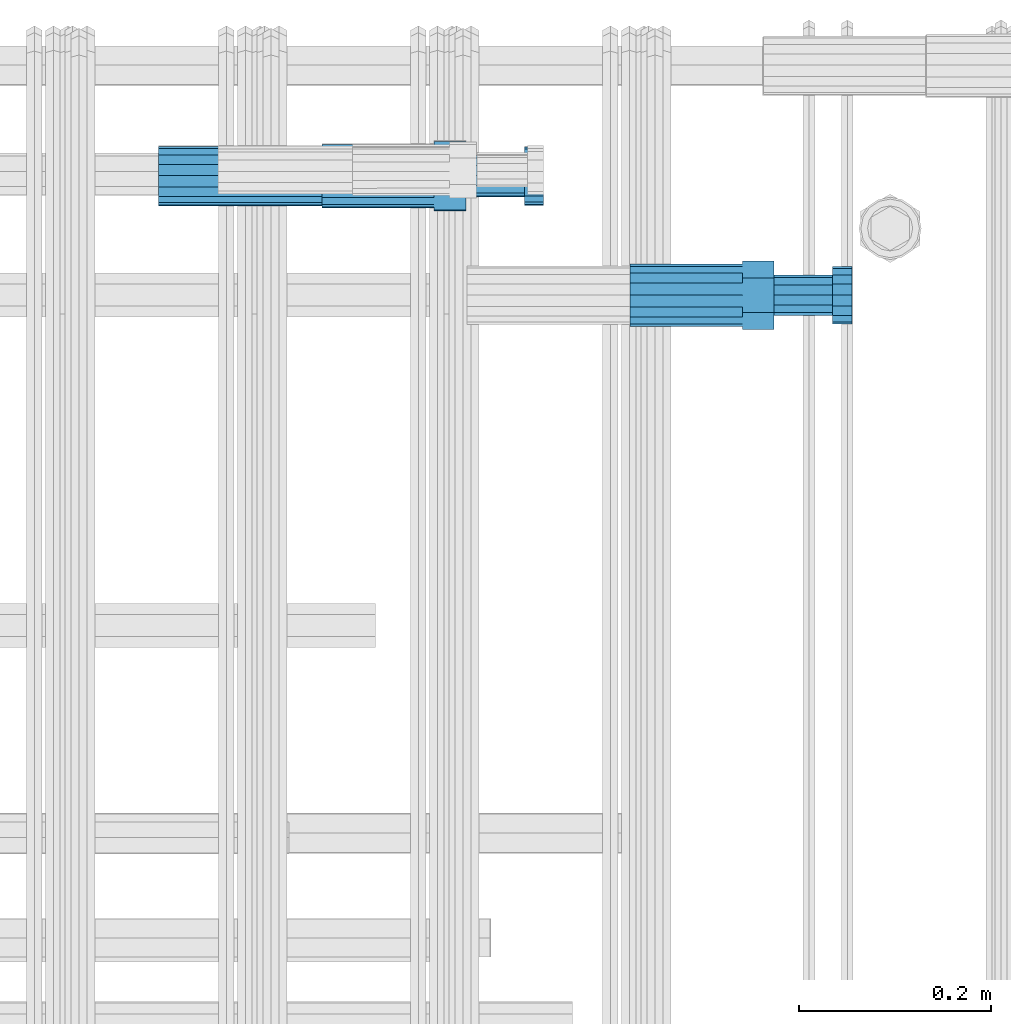
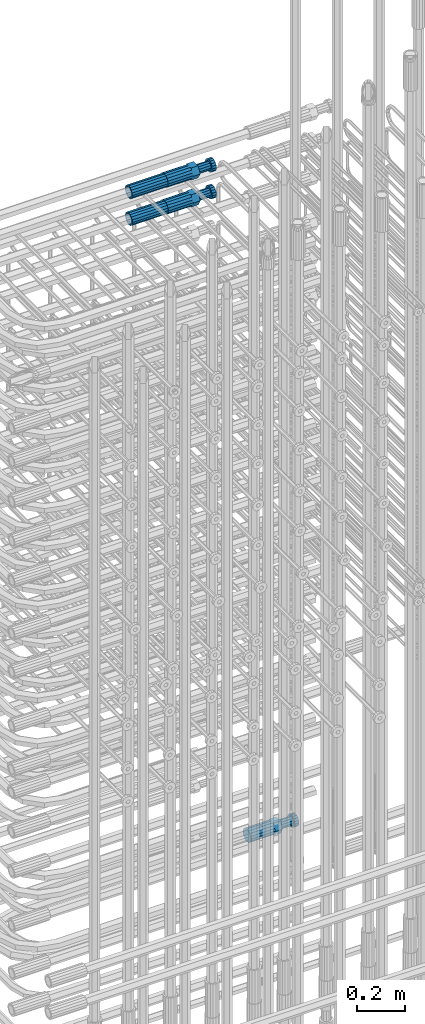
# One storey, part 44 of 177: 5 beams.
"""IFC2X3 building model written with IfcOpenShell, lengths in millimetres."""

from ifc_helpers import new_model, si_unit, frame, origin_with_axes, place, context, subcontext, project, spatial, faceted_brep, material, type_object, element, save


model = new_model("IFC2X3")

# Units and contexts
model_context_1 = context("Model", 3, precision=1e-05, world=origin_with_axes())
model_context_2 = context("Model", 3, precision=1e-05, world=origin_with_axes())
body_context = subcontext(model_context_2, "Body", "Model", "MODEL_VIEW")
ifc_project = project(units=[si_unit("LENGTHUNIT", "METRE", prefix="MILLI"), si_unit("AREAUNIT", "SQUARE_METRE"), si_unit("VOLUMEUNIT", "CUBIC_METRE"), si_unit("MASSUNIT", "GRAM", prefix="KILO"), si_unit("TIMEUNIT", "SECOND"), si_unit("PLANEANGLEUNIT", "RADIAN"), si_unit("SOLIDANGLEUNIT", "STERADIAN"), si_unit("THERMODYNAMICTEMPERATUREUNIT", "DEGREE_CELSIUS"), si_unit("LUMINOUSINTENSITYUNIT", "LUMEN")], contexts=[model_context_1])

# Site, building, storey
site_placement = place(None, origin_with_axes())
site = spatial("IfcSite", under=ifc_project, at=site_placement, CompositionType="ELEMENT")
building_placement = place(site_placement, origin_with_axes())
building = spatial("IfcBuilding", under=site, at=building_placement, Name="Undefined", CompositionType="ELEMENT")
storey_placement = place(building_placement, origin_with_axes())
storey = spatial("IfcBuildingStorey", under=building, at=storey_placement, Name="Undefined", CompositionType="ELEMENT", Elevation=0.0)

# Beams
ifc_material = material(Name="STEEL/S275")
beam_type_1 = type_object("IfcBeamType", PredefinedType="NOTDEFINED")
beam_1_placement = place(storey_placement, frame((2030819.00847313, 6206283.98588031, 22354.9868004314), z_axis=(0.0, 0.0, -1.0), x_axis=(1.0, 0.0, 0.0)))
element("IfcBeam", 1, at=beam_1_placement, inside=storey, type_object=beam_type_1, material=ifc_material, Name="AG40N", context=body_context, shape_type="Brep", body=[
    faceted_brep([(0.0, -23.5000000001164, -9.31322574615479e-10), (0.0, -21.7111690140155, 8.99306066054851), (170.0, -21.7111690140155, 8.99306066054851), (170.0, -23.5, 0.0), (0.0, -16.6170093578839, 16.6170093575493), (170.0, -16.6170093578839, 16.6170093575493), (0.0, -8.99306066057943, 21.7111690137535), (170.0, -8.99306066057943, 21.7111690137535), (0.0, 1.16415321826935e-10, 23.5), (170.0, 0.0, 23.5), (0.0, 8.99306066057943, 21.7111690137535), (170.0, 8.99306066057943, 21.7111690137535), (0.0, 16.6170093578839, 16.6170093575493), (170.0, 16.6170093578839, 16.6170093575493), (0.0, 21.7111690140155, 8.99306066054851), (170.0, 21.7111690140155, 8.99306066054851), (0.0, 23.5000000001164, -9.31322574615479e-10), (170.0, 23.5, 0.0), (0.0, 21.7111690140155, -8.99306066054851), (170.0, 21.7111690140155, -8.99306066054851), (0.0, 16.6170093578839, -16.6170093575493), (170.0, 16.6170093578839, -16.6170093575493), (0.0, 8.99306066057943, -21.7111690137535), (170.0, 8.99306066057943, -21.7111690137535), (0.0, 1.16415321826935e-10, -23.5000000009313), (170.0, 0.0, -23.5), (0.0, -8.99306066057943, -21.7111690137535), (170.0, -8.99306066057943, -21.7111690137535), (0.0, -16.6170093578839, -16.6170093575493), (170.0, -16.6170093578839, -16.6170093575493), (0.0, -21.7111690140155, -8.99306066054851), (170.0, -21.7111690140155, -8.99306066054851), (0.0, -30.5, 0.0), (0.0, -28.1783257415937, -11.6718446873128), (170.0, -28.1783257415937, -11.6718446873128), (170.0, -30.5, 0.0), (0.0, -21.5667568261888, -21.5667568258941), (170.0, -21.5667568261888, -21.5667568258941), (0.0, -11.6718446871346, -28.1783257415518), (170.0, -11.6718446871346, -28.1783257415518), (0.0, 0.0, -30.5), (170.0, 0.0, -30.5), (0.0, 11.6718446871346, -28.1783257415518), (170.0, 11.6718446871346, -28.1783257415518), (0.0, 21.5667568261888, -21.5667568258941), (170.0, 21.5667568261888, -21.5667568258941), (0.0, 28.1783257415937, -11.6718446873128), (170.0, 28.1783257415937, -11.6718446873128), (0.0, 30.5, 0.0), (170.0, 30.5, 0.0), (0.0, 28.1783257415937, 11.6718446873128), (170.0, 28.1783257415937, 11.6718446873128), (0.0, 21.5667568261888, 21.5667568258941), (170.0, 21.5667568261888, 21.5667568258941), (0.0, 11.6718446871346, 28.1783257415518), (170.0, 11.6718446871346, 28.1783257415518), (0.0, 0.0, 30.5), (170.0, 0.0, 30.5), (0.0, -11.6718446871346, 28.1783257415518), (170.0, -11.6718446871346, 28.1783257415518), (0.0, -21.5667568261888, 21.5667568258941), (170.0, -21.5667568261888, 21.5667568258941), (0.0, -28.1783257415937, 11.6718446873128), (170.0, -28.1783257415937, 11.6718446873128)], [[[0, 1, 2, 3]], [[1, 4, 5, 2]], [[4, 6, 7, 5]], [[6, 8, 9, 7]], [[8, 10, 11, 9]], [[10, 12, 13, 11]], [[12, 14, 15, 13]], [[14, 16, 17, 15]], [[16, 18, 19, 17]], [[18, 20, 21, 19]], [[20, 22, 23, 21]], [[22, 24, 25, 23]], [[24, 26, 27, 25]], [[26, 28, 29, 27]], [[28, 30, 31, 29]], [[30, 0, 3, 31]], [[32, 33, 34, 35]], [[33, 36, 37, 34]], [[36, 38, 39, 37]], [[38, 40, 41, 39]], [[40, 42, 43, 41]], [[42, 44, 45, 43]], [[44, 46, 47, 45]], [[46, 48, 49, 47]], [[48, 50, 51, 49]], [[50, 52, 53, 51]], [[52, 54, 55, 53]], [[54, 56, 57, 55]], [[56, 58, 59, 57]], [[58, 60, 61, 59]], [[60, 62, 63, 61]], [[62, 32, 35, 63]], [[37, 39, 41, 43, 45, 47, 49, 51, 53, 55, 57, 59, 61, 63, 35, 34], [5, 7, 9, 11, 13, 15, 17, 19, 21, 23, 25, 27, 29, 31, 3, 2]], [[62, 60, 58, 56, 54, 52, 50, 48, 46, 44, 42, 40, 38, 36, 33, 32], [30, 28, 26, 24, 22, 20, 18, 16, 14, 12, 10, 8, 6, 4, 1, 0]]]),
])
beam_2_placement = place(storey_placement, frame((2030819.00847313, 6206282.98588031, 22219.9868004314), z_axis=(0.0, 0.0, -1.0), x_axis=(1.0, 0.0, 0.0)))
element("IfcBeam", 2, at=beam_2_placement, inside=storey, type_object=beam_type_1, material=ifc_material, Name="AG40N", context=body_context, shape_type="Brep", body=[
    faceted_brep([(0.0, -23.5000000001164, -9.31322574615479e-10), (0.0, -21.7111690140155, 8.99306066054851), (170.0, -21.7111690140155, 8.99306066054851), (170.0, -23.5, 0.0), (0.0, -16.6170093578839, 16.6170093575493), (170.0, -16.6170093578839, 16.6170093575493), (0.0, -8.99306066057943, 21.7111690137535), (170.0, -8.99306066057943, 21.7111690137535), (0.0, 1.16415321826935e-10, 23.5), (170.0, 0.0, 23.5), (0.0, 8.99306066057943, 21.7111690137535), (170.0, 8.99306066057943, 21.7111690137535), (0.0, 16.6170093578839, 16.6170093575493), (170.0, 16.6170093578839, 16.6170093575493), (0.0, 21.7111690140155, 8.99306066054851), (170.0, 21.7111690140155, 8.99306066054851), (0.0, 23.5000000001164, -9.31322574615479e-10), (170.0, 23.5, 0.0), (0.0, 21.7111690140155, -8.99306066054851), (170.0, 21.7111690140155, -8.99306066054851), (0.0, 16.6170093578839, -16.6170093575493), (170.0, 16.6170093578839, -16.6170093575493), (0.0, 8.99306066057943, -21.7111690137535), (170.0, 8.99306066057943, -21.7111690137535), (0.0, 1.16415321826935e-10, -23.5000000009313), (170.0, 0.0, -23.5), (0.0, -8.99306066057943, -21.7111690137535), (170.0, -8.99306066057943, -21.7111690137535), (0.0, -16.6170093578839, -16.6170093575493), (170.0, -16.6170093578839, -16.6170093575493), (0.0, -21.7111690140155, -8.99306066054851), (170.0, -21.7111690140155, -8.99306066054851), (0.0, -30.5, 0.0), (0.0, -28.1783257415937, -11.6718446873128), (170.0, -28.1783257415937, -11.6718446873128), (170.0, -30.5, 0.0), (0.0, -21.5667568261888, -21.5667568258941), (170.0, -21.5667568261888, -21.5667568258941), (0.0, -11.6718446871346, -28.1783257415518), (170.0, -11.6718446871346, -28.1783257415518), (0.0, 0.0, -30.5), (170.0, 0.0, -30.5), (0.0, 11.6718446871346, -28.1783257415518), (170.0, 11.6718446871346, -28.1783257415518), (0.0, 21.5667568261888, -21.5667568258941), (170.0, 21.5667568261888, -21.5667568258941), (0.0, 28.1783257415937, -11.6718446873128), (170.0, 28.1783257415937, -11.6718446873128), (0.0, 30.5, 0.0), (170.0, 30.5, 0.0), (0.0, 28.1783257415937, 11.6718446873128), (170.0, 28.1783257415937, 11.6718446873128), (0.0, 21.5667568261888, 21.5667568258941), (170.0, 21.5667568261888, 21.5667568258941), (0.0, 11.6718446871346, 28.1783257415518), (170.0, 11.6718446871346, 28.1783257415518), (0.0, 0.0, 30.5), (170.0, 0.0, 30.5), (0.0, -11.6718446871346, 28.1783257415518), (170.0, -11.6718446871346, 28.1783257415518), (0.0, -21.5667568261888, 21.5667568258941), (170.0, -21.5667568261888, 21.5667568258941), (0.0, -28.1783257415937, 11.6718446873128), (170.0, -28.1783257415937, 11.6718446873128)], [[[0, 1, 2, 3]], [[1, 4, 5, 2]], [[4, 6, 7, 5]], [[6, 8, 9, 7]], [[8, 10, 11, 9]], [[10, 12, 13, 11]], [[12, 14, 15, 13]], [[14, 16, 17, 15]], [[16, 18, 19, 17]], [[18, 20, 21, 19]], [[20, 22, 23, 21]], [[22, 24, 25, 23]], [[24, 26, 27, 25]], [[26, 28, 29, 27]], [[28, 30, 31, 29]], [[30, 0, 3, 31]], [[32, 33, 34, 35]], [[33, 36, 37, 34]], [[36, 38, 39, 37]], [[38, 40, 41, 39]], [[40, 42, 43, 41]], [[42, 44, 45, 43]], [[44, 46, 47, 45]], [[46, 48, 49, 47]], [[48, 50, 51, 49]], [[50, 52, 53, 51]], [[52, 54, 55, 53]], [[54, 56, 57, 55]], [[56, 58, 59, 57]], [[58, 60, 61, 59]], [[60, 62, 63, 61]], [[62, 32, 35, 63]], [[37, 39, 41, 43, 45, 47, 49, 51, 53, 55, 57, 59, 61, 63, 35, 34], [5, 7, 9, 11, 13, 15, 17, 19, 21, 23, 25, 27, 29, 31, 3, 2]], [[62, 60, 58, 56, 54, 52, 50, 48, 46, 44, 42, 40, 38, 36, 33, 32], [30, 28, 26, 24, 22, 20, 18, 16, 14, 12, 10, 8, 6, 4, 1, 0]]]),
])
beam_type_2 = type_object("IfcBeamType", Name="ROD65", PredefinedType="NOTDEFINED")
beam_3_placement = place(storey_placement, frame((2031310.04841256, 6206159.48587195, 19018.4868004291), z_axis=(0.0, 0.0, -1.0), x_axis=(1.0, 0.0, 0.0)))
element("IfcBeam", 3, at=beam_3_placement, inside=storey, type_object=beam_type_2, material=ifc_material, Name="AGB40", ObjectType="ROD65", context=body_context, shape_type="Brep", body=[
    faceted_brep([(117.0, 8.17543110251427, 30.873805644922), (117.0, 17.8250000001863, 30.873805644922), (117.0, 22.0056958701462, 23.6326279877685), (117.0, 12.4372115517035, 30.0260848065373), (117.0, -17.8250000001863, 30.873805644922), (150.200000000186, -17.8250000001863, 30.873805644922), (150.200000000186, 17.8250000001863, 30.873805644922), (117.0, -8.17543110251427, 30.873805644922), (117.0, -12.4372115517035, 30.0260848065373), (117.0, -22.0056958701462, 23.6326279877685), (117.0, -35.6500000003725, 0.0), (150.200000000186, -35.6500000003725, 0.0), (117.0, -30.8443150008097, 8.32369058486074), (117.0, -32.5, 0.0), (117.0, -30.8443150008097, -8.32369058462791), (117.0, -17.8250000001863, -30.873805644922), (150.200000000186, -17.8250000001863, -30.873805644922), (117.0, -22.0056958701462, -23.6326279877685), (117.0, -12.4372115517035, -30.0260848065373), (117.0, -8.17543110251427, -30.873805644922), (117.0, 17.8250000001863, -30.873805644922), (150.200000000186, 17.8250000001863, -30.873805644922), (117.0, 8.17543110251427, -30.873805644922), (117.0, 22.0056958701462, -23.6326279877685), (117.0, 12.4372115517035, -30.0260848065373), (117.0, 35.6500000003725, 0.0), (150.200000000186, 35.6500000003725, 0.0), (117.0, 30.8443150008097, -8.32369058486074), (117.0, 30.8443150008097, 8.32369058462791), (117.0, 32.5, 0.0), (0.0, -22.9809703892097, 22.9809703885621), (0.0, -30.0260848058388, 12.4372115518636), (117.0, -30.0260848067701, 12.4372115519363), (117.0, -22.9809703882784, 22.9809703885112), (-2.3283064365387e-10, 22.9809703892097, -22.9809703885639), (-4.65661287307739e-10, 30.0260848077014, -12.4372115518672), (117.0, 30.0260848067701, -12.4372115519363), (117.0, 22.9809703882784, -22.9809703885112), (-2.3283064365387e-10, -30.0260848067701, -12.4372115518672), (-2.3283064365387e-10, -22.9809703892097, -22.9809703885621), (117.0, -22.9809703882784, -22.9809703885112), (117.0, -30.0260848067701, -12.4372115519363), (-2.3283064365387e-10, -12.4372115507722, 30.0260848066137), (-2.3283064365387e-10, 9.31322574615479e-10, 32.4999999999982), (-2.3283064365387e-10, 12.4372115526348, 30.0260848066137), (0.0, 22.9809703892097, 22.9809703885621), (-2.3283064365387e-10, 30.0260848077014, 12.4372115518636), (-2.3283064365387e-10, 32.5, 0.0), (-2.3283064365387e-10, 12.4372115526348, -30.0260848066173), (-2.3283064365387e-10, 9.31322574615479e-10, -32.5), (-2.3283064365387e-10, -12.4372115517035, -30.0260848066173), (-4.65661287307739e-10, -32.4999999990687, -1.81898940354586e-12), (117.0, 22.9809703882784, 22.9809703885112), (117.0, 30.0260848067701, 12.4372115519363), (117.0, 0.0, -32.5), (117.0, 0.0, 32.5), (150.200000000186, 10.5, -18.1865334794857), (150.200000000186, 0.0, -21.0), (150.200000000186, -10.5, -18.1865334794857), (150.200000000186, -18.18653347902, -10.5), (150.200000000186, -21.0, 0.0), (150.200000000186, -18.18653347902, 10.5), (150.200000000186, -10.5, 18.1865334794857), (150.200000000186, 0.0, 21.0), (150.200000000186, 10.5, 18.1865334794857), (150.200000000186, 18.18653347902, 10.5), (150.200000000186, 21.0, 0.0), (150.200000000186, 18.18653347902, -10.5), (210.980000000447, -18.18653347902, 10.5), (210.980000000447, -21.0, 0.0), (210.980000000447, -10.5, 18.1865334794857), (210.980000000447, 0.0, 21.0), (210.980000000447, 10.5, 18.1865334794857), (210.980000000447, 18.18653347902, 10.5), (210.980000000447, 21.0, 0.0), (210.980000000447, 18.18653347902, -10.5), (210.980000000447, 10.5, -18.1865334794857), (210.980000000447, 0.0, -21.0), (210.980000000447, -10.5, -18.1865334794857), (210.980000000447, -18.18653347902, -10.5), (211.001368442696, -27.7269937992096, -11.491116326768), (211.003082550167, -21.2238094303757, -21.223815418547), (231.002518367059, -21.2131944671273, -21.2132004550658), (231.000804259587, -27.7163788359612, -11.4805013632867), (211.001368440451, -11.4911085031927, -27.7269970395137), (231.000804257343, -11.4804935399443, -27.7163820760325), (210.996487071217, -0.0106065049767494, -30.0106107392348), (230.995922888109, 8.45827162265778e-06, -29.9999957757536), (210.989181586672, 11.46989420522, -27.7269970329944), (230.988617403564, 11.4805091684684, -27.7163820695132), (210.980564180623, 21.2025914648548, -21.2238154064398), (230.979999997515, 21.2132064281031, -21.2132004429586), (210.971946775022, 27.7057703435421, -11.4911163107026), (230.971382591913, 27.7163853067905, -11.4805013472214), (210.96464129175, 29.9893808094785, -0.0106149562634528), (230.964077108642, 29.9999957727268, 7.21774995326996e-09), (210.959759924415, 27.7057638689876, 11.4698863970116), (230.959195741307, 27.7163788322359, 11.4805013604928), (210.958045816944, 21.2025795001537, 21.2025854887906), (230.957481633835, 21.213194463402, 21.2132004522718), (210.95975992666, 11.4698785729706, 27.7057671097573), (230.959195743551, 11.480493536219, 27.7163820732385), (210.964641295894, -0.010623425245285, 29.9893808094785), (230.964077112785, -8.46199691295624e-06, 29.9999957729597), (210.971946780439, -11.4911241354421, 27.705767103238), (230.97138259733, -11.4805091721937, 27.7163820667192), (210.980564186488, -21.2238213950768, 21.2025854766835), (230.980000003379, -21.2132064318284, 21.2132004401647), (210.989181592089, -27.7270002737641, 11.4698863809463), (230.988617408981, -27.7163853105158, 11.4805013444275), (210.996487075361, -30.0106107397005, -0.0106149734929204), (230.995922892253, -29.9999957764521, -1.00117176771164e-08)], [[[0, 1, 2, 3]], [[4, 5, 6, 1, 0, 7]], [[4, 7, 8, 9]], [[10, 11, 5, 4, 9, 12]], [[10, 12, 13, 14]], [[15, 16, 11, 10, 14, 17]], [[15, 17, 18, 19]], [[20, 21, 16, 15, 19, 22]], [[23, 20, 22, 24]], [[25, 26, 21, 20, 23, 27]], [[28, 25, 27, 29]], [[30, 31, 32, 33]], [[34, 35, 36, 37]], [[38, 39, 40, 41]], [[31, 30, 42, 43, 44, 45, 46, 47, 35, 34, 48, 49, 50, 39, 38, 51]], [[46, 45, 52, 53]], [[29, 47, 46, 53, 28]], [[27, 36, 35, 47, 29]], [[23, 37, 36, 27]], [[24, 48, 34, 37, 23]], [[22, 54, 49, 48, 24]], [[19, 54, 22]], [[18, 50, 49, 54, 19]], [[17, 40, 39, 50, 18]], [[14, 41, 40, 17]], [[13, 51, 38, 41, 14]], [[12, 32, 31, 51, 13]], [[9, 33, 32, 12]], [[8, 42, 30, 33, 9]], [[7, 55, 43, 42, 8]], [[0, 55, 7]], [[3, 44, 43, 55, 0]], [[2, 52, 45, 44, 3]], [[28, 53, 52, 2]], [[1, 6, 26, 25, 28, 2]], [[5, 11, 16, 21, 26, 6], [56, 57, 58, 59, 60, 61, 62, 63, 64, 65, 66, 67]], [[68, 61, 60, 69]], [[70, 62, 61, 68]], [[71, 63, 62, 70]], [[72, 64, 63, 71]], [[73, 65, 64, 72]], [[74, 66, 65, 73]], [[75, 67, 66, 74]], [[76, 56, 67, 75]], [[77, 57, 56, 76]], [[78, 58, 57, 77]], [[79, 59, 58, 78]], [[69, 60, 59, 79]], [[80, 81, 82, 83]], [[81, 84, 85, 82]], [[84, 86, 87, 85]], [[86, 88, 89, 87]], [[88, 90, 91, 89]], [[90, 92, 93, 91]], [[92, 94, 95, 93]], [[94, 96, 97, 95]], [[96, 98, 99, 97]], [[98, 100, 101, 99]], [[100, 102, 103, 101]], [[102, 104, 105, 103]], [[104, 106, 107, 105]], [[106, 108, 109, 107]], [[108, 110, 111, 109]], [[82, 85, 87, 89, 91, 93, 95, 97, 99, 101, 103, 105, 107, 109, 111, 83]], [[110, 80, 83, 111]], [[108, 106, 104, 102, 100, 98, 96, 94, 92, 90, 88, 86, 84, 81, 80, 110], [75, 74, 73, 72, 71, 70, 68, 69, 79, 78, 77, 76]]]),
])
beam_4_placement = place(storey_placement, frame((2030989.00847313, 6206283.98588031, 22354.9868004314), z_axis=(0.0, 0.0, -1.0), x_axis=(1.0, 0.0, 0.0)))
element("IfcBeam", 4, at=beam_4_placement, inside=storey, type_object=beam_type_2, material=ifc_material, Name="AGB40", ObjectType="ROD65", context=body_context, shape_type="Brep", body=[
    faceted_brep([(117.0, 8.17543110251427, 30.873805644922), (117.0, 17.8250000001863, 30.873805644922), (117.0, 22.0056958701462, 23.6326279877685), (117.0, 12.4372115517035, 30.0260848065373), (117.0, -17.8250000001863, 30.873805644922), (150.200000000186, -17.8250000001863, 30.873805644922), (150.200000000186, 17.8250000001863, 30.873805644922), (117.0, -8.17543110251427, 30.873805644922), (117.0, -12.4372115517035, 30.0260848065373), (117.0, -22.0056958701462, 23.6326279877685), (117.0, -35.6500000003725, 0.0), (150.200000000186, -35.6500000003725, 0.0), (117.0, -30.8443150008097, 8.32369058486074), (117.0, -32.5, 0.0), (117.0, -30.8443150008097, -8.32369058462791), (117.0, -17.8250000001863, -30.873805644922), (150.200000000186, -17.8250000001863, -30.873805644922), (117.0, -22.0056958701462, -23.6326279877685), (117.0, -12.4372115517035, -30.0260848065373), (117.0, -8.17543110251427, -30.873805644922), (117.0, 17.8250000001863, -30.873805644922), (150.200000000186, 17.8250000001863, -30.873805644922), (117.0, 8.17543110251427, -30.873805644922), (117.0, 22.0056958701462, -23.6326279877685), (117.0, 12.4372115517035, -30.0260848065373), (117.0, 35.6500000003725, 0.0), (150.200000000186, 35.6500000003725, 0.0), (117.0, 30.8443150008097, -8.32369058486074), (117.0, 30.8443150008097, 8.32369058462791), (117.0, 32.5, 0.0), (0.0, -22.9809703892097, 22.9809703885621), (0.0, -30.0260848058388, 12.4372115518636), (117.0, -30.0260848067701, 12.4372115519363), (117.0, -22.9809703882784, 22.9809703885112), (-2.3283064365387e-10, 22.9809703892097, -22.9809703885639), (-4.65661287307739e-10, 30.0260848077014, -12.4372115518672), (117.0, 30.0260848067701, -12.4372115519363), (117.0, 22.9809703882784, -22.9809703885112), (-2.3283064365387e-10, -30.0260848067701, -12.4372115518672), (-2.3283064365387e-10, -22.9809703892097, -22.9809703885621), (117.0, -22.9809703882784, -22.9809703885112), (117.0, -30.0260848067701, -12.4372115519363), (-2.3283064365387e-10, -12.4372115507722, 30.0260848066137), (-2.3283064365387e-10, 9.31322574615479e-10, 32.4999999999982), (-2.3283064365387e-10, 12.4372115526348, 30.0260848066137), (0.0, 22.9809703892097, 22.9809703885621), (-2.3283064365387e-10, 30.0260848077014, 12.4372115518636), (-2.3283064365387e-10, 32.5, 0.0), (-2.3283064365387e-10, 12.4372115526348, -30.0260848066173), (-2.3283064365387e-10, 9.31322574615479e-10, -32.5), (-2.3283064365387e-10, -12.4372115517035, -30.0260848066173), (-4.65661287307739e-10, -32.4999999990687, -1.81898940354586e-12), (117.0, 22.9809703882784, 22.9809703885112), (117.0, 30.0260848067701, 12.4372115519363), (117.0, 0.0, -32.5), (117.0, 0.0, 32.5), (150.200000000186, 10.5, -18.1865334794857), (150.200000000186, 0.0, -21.0), (150.200000000186, -10.5, -18.1865334794857), (150.200000000186, -18.18653347902, -10.5), (150.200000000186, -21.0, 0.0), (150.200000000186, -18.18653347902, 10.5), (150.200000000186, -10.5, 18.1865334794857), (150.200000000186, 0.0, 21.0), (150.200000000186, 10.5, 18.1865334794857), (150.200000000186, 18.18653347902, 10.5), (150.200000000186, 21.0, 0.0), (150.200000000186, 18.18653347902, -10.5), (210.980000000447, -18.18653347902, 10.5), (210.980000000447, -21.0, 0.0), (210.980000000447, -10.5, 18.1865334794857), (210.980000000447, 0.0, 21.0), (210.980000000447, 10.5, 18.1865334794857), (210.980000000447, 18.18653347902, 10.5), (210.980000000447, 21.0, 0.0), (210.980000000447, 18.18653347902, -10.5), (210.980000000447, 10.5, -18.1865334794857), (210.980000000447, 0.0, -21.0), (210.980000000447, -10.5, -18.1865334794857), (210.980000000447, -18.18653347902, -10.5), (211.001368442696, -27.7269937992096, -11.491116326768), (211.003082550167, -21.2238094303757, -21.223815418547), (231.002518367059, -21.2131944671273, -21.2132004550658), (231.000804259587, -27.7163788359612, -11.4805013632867), (211.001368440451, -11.4911085031927, -27.7269970395137), (231.000804257343, -11.4804935399443, -27.7163820760325), (210.996487071217, -0.0106065049767494, -30.0106107392348), (230.995922888109, 8.45827162265778e-06, -29.9999957757536), (210.989181586672, 11.46989420522, -27.7269970329944), (230.988617403564, 11.4805091684684, -27.7163820695132), (210.980564180623, 21.2025914648548, -21.2238154064398), (230.979999997515, 21.2132064281031, -21.2132004429586), (210.971946775022, 27.7057703435421, -11.4911163107026), (230.971382591913, 27.7163853067905, -11.4805013472214), (210.96464129175, 29.9893808094785, -0.0106149562634528), (230.964077108642, 29.9999957727268, 7.21774995326996e-09), (210.959759924415, 27.7057638689876, 11.4698863970116), (230.959195741307, 27.7163788322359, 11.4805013604928), (210.958045816944, 21.2025795001537, 21.2025854887906), (230.957481633835, 21.213194463402, 21.2132004522718), (210.95975992666, 11.4698785729706, 27.7057671097573), (230.959195743551, 11.480493536219, 27.7163820732385), (210.964641295894, -0.010623425245285, 29.9893808094785), (230.964077112785, -8.46199691295624e-06, 29.9999957729597), (210.971946780439, -11.4911241354421, 27.705767103238), (230.97138259733, -11.4805091721937, 27.7163820667192), (210.980564186488, -21.2238213950768, 21.2025854766835), (230.980000003379, -21.2132064318284, 21.2132004401647), (210.989181592089, -27.7270002737641, 11.4698863809463), (230.988617408981, -27.7163853105158, 11.4805013444275), (210.996487075361, -30.0106107397005, -0.0106149734929204), (230.995922892253, -29.9999957764521, -1.00117176771164e-08)], [[[0, 1, 2, 3]], [[4, 5, 6, 1, 0, 7]], [[4, 7, 8, 9]], [[10, 11, 5, 4, 9, 12]], [[10, 12, 13, 14]], [[15, 16, 11, 10, 14, 17]], [[15, 17, 18, 19]], [[20, 21, 16, 15, 19, 22]], [[23, 20, 22, 24]], [[25, 26, 21, 20, 23, 27]], [[28, 25, 27, 29]], [[30, 31, 32, 33]], [[34, 35, 36, 37]], [[38, 39, 40, 41]], [[31, 30, 42, 43, 44, 45, 46, 47, 35, 34, 48, 49, 50, 39, 38, 51]], [[46, 45, 52, 53]], [[29, 47, 46, 53, 28]], [[27, 36, 35, 47, 29]], [[23, 37, 36, 27]], [[24, 48, 34, 37, 23]], [[22, 54, 49, 48, 24]], [[19, 54, 22]], [[18, 50, 49, 54, 19]], [[17, 40, 39, 50, 18]], [[14, 41, 40, 17]], [[13, 51, 38, 41, 14]], [[12, 32, 31, 51, 13]], [[9, 33, 32, 12]], [[8, 42, 30, 33, 9]], [[7, 55, 43, 42, 8]], [[0, 55, 7]], [[3, 44, 43, 55, 0]], [[2, 52, 45, 44, 3]], [[28, 53, 52, 2]], [[1, 6, 26, 25, 28, 2]], [[5, 11, 16, 21, 26, 6], [56, 57, 58, 59, 60, 61, 62, 63, 64, 65, 66, 67]], [[68, 61, 60, 69]], [[70, 62, 61, 68]], [[71, 63, 62, 70]], [[72, 64, 63, 71]], [[73, 65, 64, 72]], [[74, 66, 65, 73]], [[75, 67, 66, 74]], [[76, 56, 67, 75]], [[77, 57, 56, 76]], [[78, 58, 57, 77]], [[79, 59, 58, 78]], [[69, 60, 59, 79]], [[80, 81, 82, 83]], [[81, 84, 85, 82]], [[84, 86, 87, 85]], [[86, 88, 89, 87]], [[88, 90, 91, 89]], [[90, 92, 93, 91]], [[92, 94, 95, 93]], [[94, 96, 97, 95]], [[96, 98, 99, 97]], [[98, 100, 101, 99]], [[100, 102, 103, 101]], [[102, 104, 105, 103]], [[104, 106, 107, 105]], [[106, 108, 109, 107]], [[108, 110, 111, 109]], [[82, 85, 87, 89, 91, 93, 95, 97, 99, 101, 103, 105, 107, 109, 111, 83]], [[110, 80, 83, 111]], [[108, 106, 104, 102, 100, 98, 96, 94, 92, 90, 88, 86, 84, 81, 80, 110], [75, 74, 73, 72, 71, 70, 68, 69, 79, 78, 77, 76]]]),
])
beam_5_placement = place(storey_placement, frame((2030989.00847313, 6206282.98588031, 22219.9868004314), z_axis=(0.0, 0.0, -1.0), x_axis=(1.0, 0.0, 0.0)))
element("IfcBeam", 5, at=beam_5_placement, inside=storey, type_object=beam_type_2, material=ifc_material, Name="AGB40", ObjectType="ROD65", context=body_context, shape_type="Brep", body=[
    faceted_brep([(117.0, 8.17543110251427, 30.873805644922), (117.0, 17.8250000001863, 30.873805644922), (117.0, 22.0056958701462, 23.6326279877685), (117.0, 12.4372115517035, 30.0260848065373), (117.0, -17.8250000001863, 30.873805644922), (150.200000000186, -17.8250000001863, 30.873805644922), (150.200000000186, 17.8250000001863, 30.873805644922), (117.0, -8.17543110251427, 30.873805644922), (117.0, -12.4372115517035, 30.0260848065373), (117.0, -22.0056958701462, 23.6326279877685), (117.0, -35.6500000003725, 0.0), (150.200000000186, -35.6500000003725, 0.0), (117.0, -30.8443150008097, 8.32369058486074), (117.0, -32.5, 0.0), (117.0, -30.8443150008097, -8.32369058462791), (117.0, -17.8250000001863, -30.873805644922), (150.200000000186, -17.8250000001863, -30.873805644922), (117.0, -22.0056958701462, -23.6326279877685), (117.0, -12.4372115517035, -30.0260848065373), (117.0, -8.17543110251427, -30.873805644922), (117.0, 17.8250000001863, -30.873805644922), (150.200000000186, 17.8250000001863, -30.873805644922), (117.0, 8.17543110251427, -30.873805644922), (117.0, 22.0056958701462, -23.6326279877685), (117.0, 12.4372115517035, -30.0260848065373), (117.0, 35.6500000003725, 0.0), (150.200000000186, 35.6500000003725, 0.0), (117.0, 30.8443150008097, -8.32369058486074), (117.0, 30.8443150008097, 8.32369058462791), (117.0, 32.5, 0.0), (0.0, -22.9809703892097, 22.9809703885621), (0.0, -30.0260848058388, 12.4372115518636), (117.0, -30.0260848067701, 12.4372115519363), (117.0, -22.9809703882784, 22.9809703885112), (-2.3283064365387e-10, 22.9809703892097, -22.9809703885639), (-4.65661287307739e-10, 30.0260848077014, -12.4372115518672), (117.0, 30.0260848067701, -12.4372115519363), (117.0, 22.9809703882784, -22.9809703885112), (-2.3283064365387e-10, -30.0260848067701, -12.4372115518672), (-2.3283064365387e-10, -22.9809703892097, -22.9809703885621), (117.0, -22.9809703882784, -22.9809703885112), (117.0, -30.0260848067701, -12.4372115519363), (-2.3283064365387e-10, -12.4372115507722, 30.0260848066137), (-2.3283064365387e-10, 9.31322574615479e-10, 32.4999999999982), (-2.3283064365387e-10, 12.4372115526348, 30.0260848066137), (0.0, 22.9809703892097, 22.9809703885621), (-2.3283064365387e-10, 30.0260848077014, 12.4372115518636), (-2.3283064365387e-10, 32.5, 0.0), (-2.3283064365387e-10, 12.4372115526348, -30.0260848066173), (-2.3283064365387e-10, 9.31322574615479e-10, -32.5), (-2.3283064365387e-10, -12.4372115517035, -30.0260848066173), (-4.65661287307739e-10, -32.4999999990687, -1.81898940354586e-12), (117.0, 22.9809703882784, 22.9809703885112), (117.0, 30.0260848067701, 12.4372115519363), (117.0, 0.0, -32.5), (117.0, 0.0, 32.5), (150.200000000186, 10.5, -18.1865334794857), (150.200000000186, 0.0, -21.0), (150.200000000186, -10.5, -18.1865334794857), (150.200000000186, -18.18653347902, -10.5), (150.200000000186, -21.0, 0.0), (150.200000000186, -18.18653347902, 10.5), (150.200000000186, -10.5, 18.1865334794857), (150.200000000186, 0.0, 21.0), (150.200000000186, 10.5, 18.1865334794857), (150.200000000186, 18.18653347902, 10.5), (150.200000000186, 21.0, 0.0), (150.200000000186, 18.18653347902, -10.5), (210.980000000447, -18.18653347902, 10.5), (210.980000000447, -21.0, 0.0), (210.980000000447, -10.5, 18.1865334794857), (210.980000000447, 0.0, 21.0), (210.980000000447, 10.5, 18.1865334794857), (210.980000000447, 18.18653347902, 10.5), (210.980000000447, 21.0, 0.0), (210.980000000447, 18.18653347902, -10.5), (210.980000000447, 10.5, -18.1865334794857), (210.980000000447, 0.0, -21.0), (210.980000000447, -10.5, -18.1865334794857), (210.980000000447, -18.18653347902, -10.5), (211.001368442696, -27.7269937992096, -11.491116326768), (211.003082550167, -21.2238094303757, -21.223815418547), (231.002518367059, -21.2131944671273, -21.2132004550658), (231.000804259587, -27.7163788359612, -11.4805013632867), (211.001368440451, -11.4911085031927, -27.7269970395137), (231.000804257343, -11.4804935399443, -27.7163820760325), (210.996487071217, -0.0106065049767494, -30.0106107392348), (230.995922888109, 8.45827162265778e-06, -29.9999957757536), (210.989181586672, 11.46989420522, -27.7269970329944), (230.988617403564, 11.4805091684684, -27.7163820695132), (210.980564180623, 21.2025914648548, -21.2238154064398), (230.979999997515, 21.2132064281031, -21.2132004429586), (210.971946775022, 27.7057703435421, -11.4911163107026), (230.971382591913, 27.7163853067905, -11.4805013472214), (210.96464129175, 29.9893808094785, -0.0106149562634528), (230.964077108642, 29.9999957727268, 7.21774995326996e-09), (210.959759924415, 27.7057638689876, 11.4698863970116), (230.959195741307, 27.7163788322359, 11.4805013604928), (210.958045816944, 21.2025795001537, 21.2025854887906), (230.957481633835, 21.213194463402, 21.2132004522718), (210.95975992666, 11.4698785729706, 27.7057671097573), (230.959195743551, 11.480493536219, 27.7163820732385), (210.964641295894, -0.010623425245285, 29.9893808094785), (230.964077112785, -8.46199691295624e-06, 29.9999957729597), (210.971946780439, -11.4911241354421, 27.705767103238), (230.97138259733, -11.4805091721937, 27.7163820667192), (210.980564186488, -21.2238213950768, 21.2025854766835), (230.980000003379, -21.2132064318284, 21.2132004401647), (210.989181592089, -27.7270002737641, 11.4698863809463), (230.988617408981, -27.7163853105158, 11.4805013444275), (210.996487075361, -30.0106107397005, -0.0106149734929204), (230.995922892253, -29.9999957764521, -1.00117176771164e-08)], [[[0, 1, 2, 3]], [[4, 5, 6, 1, 0, 7]], [[4, 7, 8, 9]], [[10, 11, 5, 4, 9, 12]], [[10, 12, 13, 14]], [[15, 16, 11, 10, 14, 17]], [[15, 17, 18, 19]], [[20, 21, 16, 15, 19, 22]], [[23, 20, 22, 24]], [[25, 26, 21, 20, 23, 27]], [[28, 25, 27, 29]], [[30, 31, 32, 33]], [[34, 35, 36, 37]], [[38, 39, 40, 41]], [[31, 30, 42, 43, 44, 45, 46, 47, 35, 34, 48, 49, 50, 39, 38, 51]], [[46, 45, 52, 53]], [[29, 47, 46, 53, 28]], [[27, 36, 35, 47, 29]], [[23, 37, 36, 27]], [[24, 48, 34, 37, 23]], [[22, 54, 49, 48, 24]], [[19, 54, 22]], [[18, 50, 49, 54, 19]], [[17, 40, 39, 50, 18]], [[14, 41, 40, 17]], [[13, 51, 38, 41, 14]], [[12, 32, 31, 51, 13]], [[9, 33, 32, 12]], [[8, 42, 30, 33, 9]], [[7, 55, 43, 42, 8]], [[0, 55, 7]], [[3, 44, 43, 55, 0]], [[2, 52, 45, 44, 3]], [[28, 53, 52, 2]], [[1, 6, 26, 25, 28, 2]], [[5, 11, 16, 21, 26, 6], [56, 57, 58, 59, 60, 61, 62, 63, 64, 65, 66, 67]], [[68, 61, 60, 69]], [[70, 62, 61, 68]], [[71, 63, 62, 70]], [[72, 64, 63, 71]], [[73, 65, 64, 72]], [[74, 66, 65, 73]], [[75, 67, 66, 74]], [[76, 56, 67, 75]], [[77, 57, 56, 76]], [[78, 58, 57, 77]], [[79, 59, 58, 78]], [[69, 60, 59, 79]], [[80, 81, 82, 83]], [[81, 84, 85, 82]], [[84, 86, 87, 85]], [[86, 88, 89, 87]], [[88, 90, 91, 89]], [[90, 92, 93, 91]], [[92, 94, 95, 93]], [[94, 96, 97, 95]], [[96, 98, 99, 97]], [[98, 100, 101, 99]], [[100, 102, 103, 101]], [[102, 104, 105, 103]], [[104, 106, 107, 105]], [[106, 108, 109, 107]], [[108, 110, 111, 109]], [[82, 85, 87, 89, 91, 93, 95, 97, 99, 101, 103, 105, 107, 109, 111, 83]], [[110, 80, 83, 111]], [[108, 106, 104, 102, 100, 98, 96, 94, 92, 90, 88, 86, 84, 81, 80, 110], [75, 74, 73, 72, 71, 70, 68, 69, 79, 78, 77, 76]]]),
])

save(model, "model.ifc")
